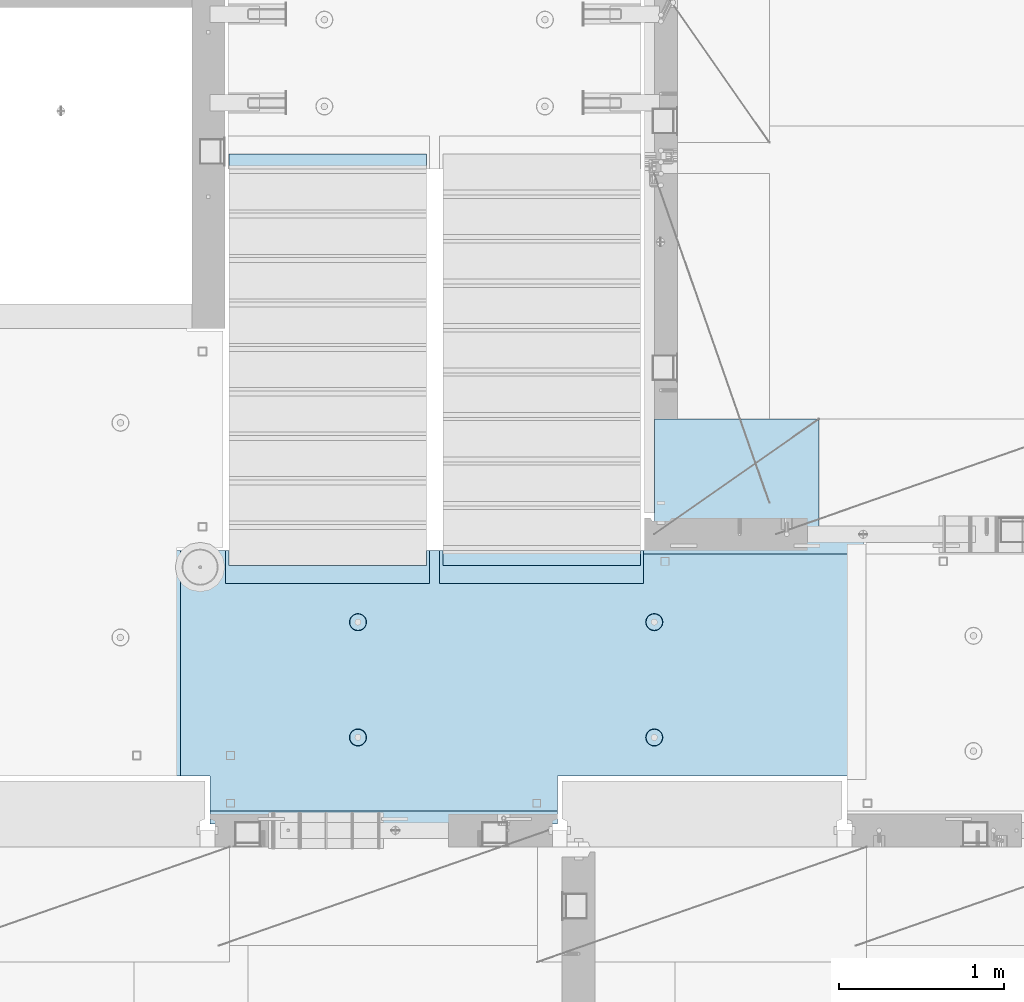
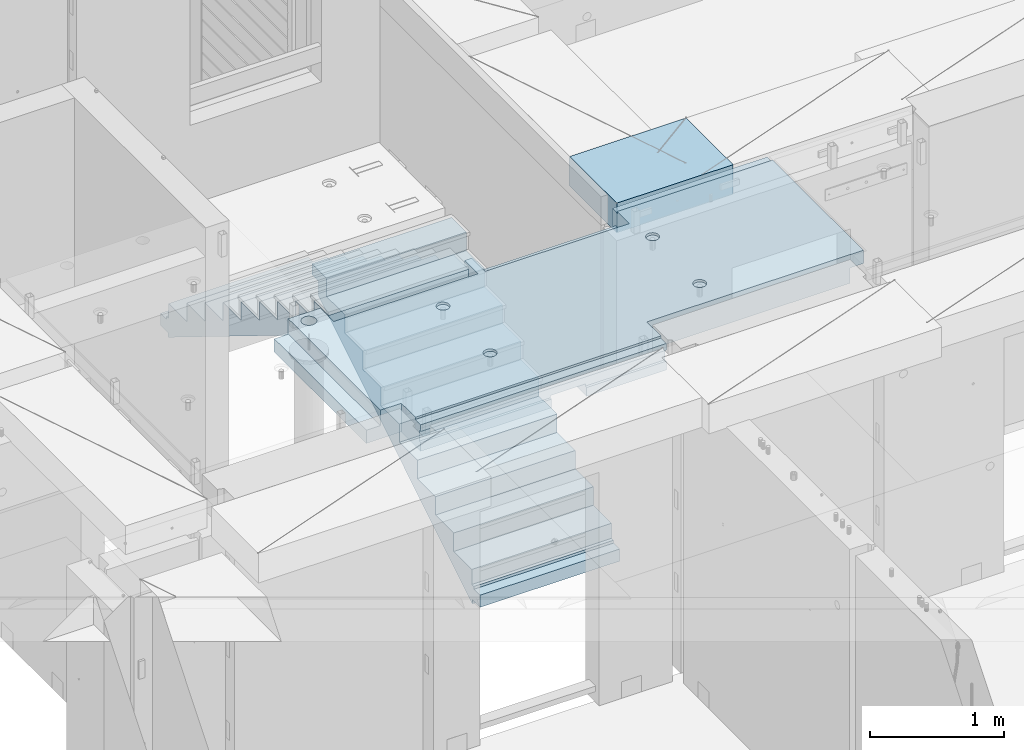
# One storey, part 187 of 325: 3 plates, 1 slab, 4 elements without a shape of their own.
"""IFC2X3 building model written with IfcOpenShell, lengths in millimetres."""

import ifcopenshell
import ifcopenshell.guid

model = None  # the IFC model being written
_history = None  # IfcOwnerHistory: only IFC2X3 demands one
_inside = {}  # id of a spatial element -> (the spatial element, [elements in it])
_under = {}  # id of a project, library or spatial element -> (it, [spatial elements below it])
_declared = {}  # id of a project -> (the project, [libraries it declares])
_typed = {}  # id of a type object -> (the type object, [elements of that type])
_made_of = {}  # id of a material, layer set ... -> (it, [elements and type objects made of it])


def new_model(schema):
    """Start an empty IFC model of exactly this schema.

    Asked for "IFC4X3", IfcOpenShell would pick the latest addendum, in which some entities
    have other attributes; the version numbers below select the first issue.
    IFC2X3 requires an IfcOwnerHistory on every rooted entity: one is made here for all.
    """
    global model, _history
    if schema == "IFC4X3":
        model = ifcopenshell.file(schema_version=(4, 3, 0, 0))
    else:
        model = ifcopenshell.file(schema=schema)
    _inside.clear()
    _under.clear()
    _declared.clear()
    _typed.clear()
    _made_of.clear()
    _history = None
    if model.schema == "IFC2X3":
        org = make("IfcOrganization", Name="unknown")
        user = make(
            "IfcPersonAndOrganization",
            ThePerson=make("IfcPerson", FamilyName="unknown"),
            TheOrganization=org,
        )
        app = make(
            "IfcApplication",
            ApplicationDeveloper=org,
            Version="unknown",
            ApplicationFullName="unknown",
            ApplicationIdentifier="unknown",
        )
        _history = make(
            "IfcOwnerHistory",
            OwningUser=user,
            OwningApplication=app,
            ChangeAction="ADDED",
            CreationDate=0,
        )
    return model


def make(cls, **values):
    """One entity of the class cls with the attributes given. An attribute that is None is left unset."""
    return model.create_entity(
        cls, **{name: value for name, value in values.items() if value is not None}
    )


def rooted(cls, **values):
    """An entity with a GlobalId (a new one), such as an element, a storey or a relation."""
    return make(cls, GlobalId=ifcopenshell.guid.new(), OwnerHistory=_history, **values)


def si_unit(unit_type, name, prefix=None):
    """IfcSIUnit, for example si_unit("LENGTHUNIT", "METRE", prefix="MILLI")."""
    return make("IfcSIUnit", UnitType=unit_type, Prefix=prefix, Name=name)


def assignment(units):
    """IfcUnitAssignment: the units of a project."""
    return None if units is None else make("IfcUnitAssignment", Units=units)


def point(xyz):
    """IfcCartesianPoint."""
    return None if xyz is None else make("IfcCartesianPoint", Coordinates=xyz)


def direction(xyz):
    """IfcDirection."""
    return None if xyz is None else make("IfcDirection", DirectionRatios=xyz)


def frame(location, z_axis=None, x_axis=None):
    """IfcAxis2Placement3D, a coordinate frame: its origin and axes. An axis left out is left unset."""
    return make(
        "IfcAxis2Placement3D",
        Location=point(location),
        Axis=direction(z_axis),
        RefDirection=direction(x_axis),
    )


def origin_with_axes():
    """The frame at (0, 0, 0) with the z axis (0, 0, 1) and the x axis (1, 0, 0) written out."""
    return frame((0.0, 0.0, 0.0), z_axis=(0.0, 0.0, 1.0), x_axis=(1.0, 0.0, 0.0))


def place(relative_to, where):
    """IfcLocalPlacement: puts the frame where relative to a parent placement (None: the world)."""
    return make(
        "IfcLocalPlacement", PlacementRelTo=relative_to, RelativePlacement=where
    )


def context(
    kind, dimensions, precision=None, world=None, true_north=None, identifier=None
):
    """IfcGeometricRepresentationContext, for example the 3D "Model" context."""
    return make(
        "IfcGeometricRepresentationContext",
        ContextIdentifier=identifier,
        ContextType=kind,
        CoordinateSpaceDimension=dimensions,
        Precision=precision,
        WorldCoordinateSystem=world,
        TrueNorth=true_north,
    )


def subcontext(parent, identifier, kind, view, scale=None):
    """IfcGeometricRepresentationSubContext, for example "Body" below "Model"."""
    return make(
        "IfcGeometricRepresentationSubContext",
        ContextIdentifier=identifier,
        ContextType=kind,
        ParentContext=parent,
        TargetScale=scale,
        TargetView=view,
    )


def project(units=None, contexts=None):
    """IfcProject with its units and contexts."""
    return rooted(
        "IfcProject",
        Name="project",
        RepresentationContexts=contexts,
        UnitsInContext=assignment(units),
    )


def spatial(cls, under=None, at=None, **own):
    """A site, building, storey or space (cls), placed at a placement, below another one or the project."""
    s = rooted(cls, ObjectPlacement=at, **own)
    if under is not None:
        _under.setdefault(under.id(), (under, []))[1].append(s)
    return s


def faces_of(points, faces, orient=None, outer=None):
    """IfcFace entities. A face is a list of loops; a loop is a list of indices into points, from 0.

    orient and outer hold one flag for each loop. By default every Orientation is true, the
    first loop of a face is its IfcFaceOuterBound and the others are IfcFaceBound.
    """
    made = []
    for i, loops in enumerate(faces):
        bounds = []
        for j, loop in enumerate(loops):
            is_outer = j == 0 if outer is None else outer[i][j]
            bounds.append(
                make(
                    "IfcFaceOuterBound" if is_outer else "IfcFaceBound",
                    Bound=make("IfcPolyLoop", Polygon=[points[k] for k in loop]),
                    Orientation=True if orient is None else orient[i][j],
                )
            )
        made.append(make("IfcFace", Bounds=bounds))
    return made


def faceted_brep(points, faces, orient=None, outer=None, voids=None):
    """IfcFacetedBrep: a solid bounded by flat faces; with voids (closed shells), ...WithVoids."""
    shared = [point(p) for p in points]
    hull = make("IfcClosedShell", CfsFaces=faces_of(shared, faces, orient, outer))
    if voids is None:
        return make("IfcFacetedBrep", Outer=hull)
    return make(
        "IfcFacetedBrepWithVoids",
        Outer=hull,
        Voids=[
            make(cls, CfsFaces=faces_of(shared, fs, o, b)) for cls, fs, o, b in voids
        ],
    )


def shape(context_of_items, identifier, shape_type, items):
    """IfcShapeRepresentation: the items that make up one representation, for example the "Body"."""
    return make(
        "IfcShapeRepresentation",
        ContextOfItems=context_of_items,
        RepresentationIdentifier=identifier,
        RepresentationType=shape_type,
        Items=items,
    )


def material(Name=None, Category=None):
    """IfcMaterial."""
    return make("IfcMaterial", Name=Name, Category=Category)


def made_of(thing, what):
    """Note that an element or type object is made of a material, layer set ...; save() writes the relation."""
    if what is not None:
        _made_of.setdefault(what.id(), (what, []))[1].append(thing)
    return thing


def type_object(cls, material=None, **own):
    """A type object (cls), such as IfcWallType, which elements share."""
    return made_of(rooted(cls, **own), material)


def element(
    cls,
    number,
    at=None,
    inside=None,
    cuts=None,
    type_object=None,
    material=None,
    context=None,
    identifier="Body",
    shape_type=None,
    held_by="IfcProductDefinitionShape",
    body=None,
    shapes=None,
    **own,
):
    """One element of the class cls, such as IfcWall. Its Tag is "e" and its number.

    at: its placement. inside: the storey or other place that contains it. cuts: it is an
    opening in that element (IfcRelVoidsElement). A single representation is given by context,
    identifier, shape_type and body (its items); several are given by shapes. held_by: the class
    of the entity that holds the representations. save() writes the other relations.
    """
    e = rooted(cls, Tag="e%d" % number, ObjectPlacement=at, **own)
    if body is not None:
        shapes = [shape(context, identifier, shape_type, body)]
    if shapes is not None:
        e.Representation = make(held_by, Representations=shapes)
    if inside is not None:
        _inside.setdefault(inside.id(), (inside, []))[1].append(e)
    if cuts is not None:
        rooted(
            "IfcRelVoidsElement", RelatingBuildingElement=cuts, RelatedOpeningElement=e
        )
    if type_object is not None:
        _typed.setdefault(type_object.id(), (type_object, []))[1].append(e)
    return made_of(e, material)


def aggregate(whole, parts):
    """IfcRelAggregates: a whole, such as a stair, and the parts it consists of."""
    return rooted("IfcRelAggregates", RelatingObject=whole, RelatedObjects=parts)


def save(model, path):
    """Write the relations noted so far, then the file.

    IfcRelAggregates (storeys below a building ...), IfcRelContainedInSpatialStructure (elements
    in a storey), IfcRelDefinesByType, IfcRelAssociatesMaterial and IfcRelDeclares: one each for
    every whole, place, type object, material and project.
    """
    for whole, parts in _under.values():
        aggregate(whole, parts)
    for where, things in _inside.values():
        rooted(
            "IfcRelContainedInSpatialStructure",
            RelatedElements=things,
            RelatingStructure=where,
        )
    for kind, things in _typed.values():
        rooted("IfcRelDefinesByType", RelatedObjects=things, RelatingType=kind)
    for what, things in _made_of.values():
        rooted("IfcRelAssociatesMaterial", RelatedObjects=things, RelatingMaterial=what)
    for by, libraries in _declared.values():
        rooted("IfcRelDeclares", RelatingContext=by, RelatedDefinitions=libraries)
    model.write(path)


model = new_model("IFC2X3")

# Units and contexts
model_context = context("Model", 3, precision=1e-05, world=origin_with_axes())
body_context = subcontext(model_context, "Body", "Model", "MODEL_VIEW")
ifc_project = project(units=[si_unit("LENGTHUNIT", "METRE", prefix="MILLI"), si_unit("AREAUNIT", "SQUARE_METRE"), si_unit("VOLUMEUNIT", "CUBIC_METRE"), si_unit("MASSUNIT", "GRAM", prefix="KILO"), si_unit("TIMEUNIT", "SECOND"), si_unit("PLANEANGLEUNIT", "RADIAN"), si_unit("SOLIDANGLEUNIT", "STERADIAN"), si_unit("THERMODYNAMICTEMPERATUREUNIT", "DEGREE_CELSIUS"), si_unit("LUMINOUSINTENSITYUNIT", "LUMEN")], contexts=[model_context])

# Site, building, storey
site_placement = place(None, origin_with_axes())
site = spatial("IfcSite", under=ifc_project, at=site_placement, CompositionType="ELEMENT")
building_placement = place(site_placement, origin_with_axes())
building = spatial("IfcBuilding", under=site, at=building_placement, CompositionType="ELEMENT")
storey_placement = place(building_placement, origin_with_axes())
storey = spatial("IfcBuildingStorey", under=building, at=storey_placement, Name="1", CompositionType="ELEMENT", Elevation=0.0)

# Assembly, slab
assembly_1_placement = place(storey_placement, origin_with_axes())
assembly_1 = element("IfcElementAssembly", 1, at=assembly_1_placement, inside=storey, AssemblyPlace="NOTDEFINED", PredefinedType="REINFORCEMENT_UNIT")
ifc_material_1 = material(Name="CONCRETE/C25/30")
slab_type = type_object("IfcSlabType", PredefinedType="NOTDEFINED")
slab_placement = place(assembly_1_placement, frame((23540.0159390845, 15510.0026483125, 84620.0), z_axis=(-0.999999999997437, -2.26400000064461e-06, 0.0), x_axis=(-2.2639999995273e-06, 0.999999999997437, 0.0)))
slab = element("IfcSlab", 2, at=slab_placement, type_object=slab_type, material=ifc_material_1, PredefinedType="FLOOR", context=body_context, shape_type="Brep", body=[
    faceted_brep([(-269.991394356101, 30.0, 2845.00213671412), (-79.9935682977648, 30.0, 2845.00213671301), (-79.9942474988402, 30.0, 2545.001661275), (-269.991475956112, 30.0, 2545.00209142873), (-79.9935682977648, 130.0, 2845.00213671301), (-269.991394356102, 50.0011356208415, 2845.00213671412), (-289.993566176285, 50.0011356208415, 2845.00213671423), (-289.993566176285, 130.0, 2845.00213671423), (-79.9942474988402, 130.0, 2545.001661275), (-289.994243058944, 130.0, 2545.00213671499), (-289.994243058944, 50.0011356208415, 2545.00213671499), (-269.991475956114, 50.0011356208415, 2545.00209142873), (250.667816023648, -110.0, 1223.00869116667), (264.606228919523, -110.0, 1230.11066726268), (275.667816023648, -110.0, 1241.1722543668), (282.76979211966, -110.0, 1255.11066726268), (285.216966304903, -110.0, 1270.56151698143), (282.769792119658, -110.0, 1286.01236670018), (275.667816023648, -110.0, 1299.95077959605), (264.606228919525, -110.0, 1311.01236670018), (250.667816023648, -110.0, 1318.11434279619), (235.216966304901, -110.0, 1320.56151698143), (219.766116586154, -110.0, 1318.11434279619), (205.827703690276, -110.0, 1311.01236670018), (194.766116586154, -110.0, 1299.95077959605), (187.664140490142, -110.0, 1286.01236670018), (185.216966304899, -110.0, 1270.56151698143), (187.664140490144, -110.0, 1255.11066726268), (194.766116586154, -110.0, 1241.1722543668), (205.827703690276, -110.0, 1230.11066726268), (219.766116586154, -110.0, 1223.00869116667), (235.216966304901, -110.0, 1220.56151698143), (251.370127374501, -130.0, 1220.84719908418), (235.216966304901, -130.0, 1218.2887897087), (265.942104492917, -130.0, 1228.27199227546), (277.506491010863, -130.0, 1239.83637879341), (284.931284202146, -130.0, 1254.40835591183), (287.489693577627, -130.0, 1270.56151698143), (284.931284202146, -130.0, 1286.71467805103), (277.506491010861, -130.0, 1301.28665516945), (265.942104492917, -130.0, 1312.85104168739), (251.370127374501, -130.0, 1320.27583487867), (235.216966304901, -130.0, 1322.83424425416), (219.063805235301, -130.0, 1320.27583487867), (204.491828116883, -130.0, 1312.85104168739), (192.927441598938, -130.0, 1301.28665516945), (185.502648407655, -130.0, 1286.71467805103), (182.944239032175, -130.0, 1270.56151698143), (185.502648407655, -130.0, 1254.40835591183), (192.92744159894, -130.0, 1239.83637879341), (204.491828116883, -130.0, 1228.27199227546), (219.063805235301, -130.0, 1220.84719908418), (1370.00988769532, 9.99999999994179, 4270.0029296875), (0.00703133410206647, 9.99999999994179, 4270.00341796875), (0.00594789032584231, 9.99999999994179, 4150.00335886026), (1370.00950450419, 9.99999999994179, 4150.0022190173), (1370.00988769532, 130.0, 4270.0029296875), (0.00703133410206647, 130.0, 4270.00341796875), (-289.995788574217, 50.0011356208415, 1860.01696777343), (-269.99166227209, 50.0011356208415, 1860.01689198933), (-289.995788574217, 130.0, 1860.01696777343), (1410.00403637765, -10.0000000000582, 115.00218916441), (-0.000334584017764428, -10.0000000000582, 115.003668258996), (-0.000334584015945438, 130.0, 115.003668258996), (1430.00436377147, 130.0, 115.002168181909), (1430.00283514406, 50.0011356437899, 115.002168184747), (1410.00403637764, 50.0011356208415, 115.002189163421), (1430.00659179688, 130.0, 1330.01220703125), (1370.00036621094, 130.0, 1330.01281738281), (1370.00036621094, -110.000000000073, 1330.01281738281), (1430.00659179688, -110.000000000073, 1330.01220703125), (1430.00656714066, -110.000000000073, 1.33804860524833e-08), (1350.00656713971, -110.000000000073, -1.09139364212751e-10), (1350.00656713971, -130.0, -9.31322574615479e-10), (0.0, -130.0, -3.63797880709171e-12), (0.0, -10.0, 0.0), (1410.00416932017, -10.0000000000582, 1.69893610291183e-09), (1410.00416932017, -49.9988643791585, 5.89352566748858e-10), (1430.00416932019, -49.9988643791585, 2.83398549072444e-09), (1430.00277003324, 50.0011356208415, 1270.01537795496), (1430.00277003324, -49.9988643791585, 1270.01537795496), (1410.00277003325, 50.0011356208415, 1270.01535591496), (1410.00277003325, -49.9988643791585, 1270.01535591496), (-0.00148380931932479, -130.0, 510.016937255856), (-0.00148380931932479, 130.0, 510.016937255856), (0.00156440050341189, -130.0, 1860.01586914062), (0.00156440050341189, 130.0, 1860.01586914062), (-209.991713751984, -130.000000000058, 1860.01666468411), (-209.996345203012, -130.0, 3970.01713194715), (-209.996345203012, -110.000000000058, 3970.01713194715), (-209.991713751984, -110.000000000058, 1860.01666468411), (-289.991027832028, -110.000000000058, 3970.01733398437), (-289.995788574217, -110.000000000058, 1860.01696777343), (-289.991027832028, -49.9988643791585, 3970.01733398437), (-289.995788574217, -49.9988643791585, 1860.01696777343), (-269.99166227209, -49.9988643791585, 1860.01689198933), (-289.991027832028, 50.0011356208415, 3970.01733398437), (-289.991027832028, 130.0, 3970.01733398437), (-269.991088351981, 50.0011356208415, 3970.01728347186), (-269.991088351981, -49.9988643791585, 3970.01728347186), (0.00432284502676339, -130.0, 3970.0166015625), (0.00432284502676339, 130.0, 3970.0166015625), (0.00594789032584231, -130.0, 4150.00335886026), (1370.00950450419, -130.000000000058, 4150.0022190173), (1370.00860847198, 9.99639270307671, 3875.01157736929), (1170.00318277859, 9.99639270307671, 3875.01203018158), (1170.00037541444, 9.99639270307671, 2635.01019913007), (1370.00459258838, 9.99639270307671, 2635.00974632052), (1370.00860847197, -130.000000000058, 3875.01157736929), (1170.00318277859, -130.000000000029, 3875.01203018158), (1170.00037541444, -130.000000000029, 2635.01019913007), (1370.00459258838, -130.000000000029, 2635.00974632052), (1370.00439827764, -130.000000000029, 2575.01157737549), (1170.00023957859, -130.000000000029, 2575.01203018491), (1170.00023957859, 9.99639270307671, 2575.01203018491), (1370.00439827764, 9.99639270307671, 2575.01157737549), (1169.99743221444, -130.000000000029, 1335.0101991334), (1169.99743221444, 9.99639270307671, 1335.0101991334), (1370.00038239405, 9.99639270307671, 1335.00974632672), (1370.00038239405, -110.000000000073, 1335.00974632672), (1350.00004294686, -110.000000000073, 1335.00979160748), (1350.00004294686, -130.000000000073, 1335.00979160748), (920.332855772751, -110.0, 1318.11282667454), (906.394410719273, -110.0, 1311.01091369173), (895.332773528397, -110.0, 1299.94937667459), (888.230734319324, -110.0, 1286.01099593661), (885.78349017266, -110.0, 1270.56015729882), (888.230594396427, -110.0, 1255.10929649942), (895.332507379233, -110.0, 1241.17085144594), (906.394044396377, -110.0, 1230.10921425507), (920.332425134358, -110.0, 1223.00717504599), (935.783263772144, -110.0, 1220.55993089933), (951.234124571543, -110.0, 1223.0070351231), (965.172569625021, -110.0, 1230.10894810591), (976.234206815898, -110.0, 1241.17048512305), (983.33624602497, -110.0, 1255.10886586103), (985.783490171634, -110.0, 1270.55970449882), (983.336385947867, -110.0, 1286.01056529821), (976.234472965061, -110.0, 1299.94901035169), (965.172935947918, -110.0, 1311.01064754257), (951.234555209936, -110.0, 1318.11268675164), (935.783716572147, -110.0, 1320.5599308983), (951.936426135147, -130.0, 1220.84553986057), (935.783253481237, -130.0, 1218.28720362663), (966.508436872882, -130.0, 1228.27026706986), (978.072875754253, -130.0, 1239.83460122415), (985.497734927369, -130.0, 1254.40654472295), (988.05621744434, -130.0, 1270.55969420791), (985.497881210395, -130.0, 1286.71286686182), (978.073154001104, -130.0, 1301.28487759955), (966.508819846818, -130.0, 1312.84931648092), (951.936876348012, -130.0, 1320.27417565404), (935.783726863054, -130.0, 1322.83265817101), (919.630554209147, -130.0, 1320.27432193707), (905.058543471412, -130.0, 1312.84959472777), (893.494104590041, -130.0, 1301.28526057349), (886.069245416922, -130.0, 1286.71331707469), (883.510762899954, -130.0, 1270.56016758973), (886.069099133892, -130.0, 1254.40699493582), (893.49382634319, -130.0, 1239.83498419809), (905.058160497476, -130.0, 1228.27054531671), (919.630103996282, -130.0, 1220.84568614359), (920.336931380272, -110.0, 3118.29282666992), (906.398486326791, -110.0, 3111.19091368712), (895.336849135918, -110.0, 3100.12937666997), (888.234809926846, -110.0, 3086.19099593199), (885.787565780181, -110.0, 3070.7401572942), (888.234670003949, -110.0, 3055.28929649481), (895.336582986754, -110.0, 3041.35085144133), (906.398120003898, -110.0, 3030.28921425045), (920.33650074188, -110.0, 3023.18717504138), (935.787339379665, -110.0, 3020.73993089472), (951.238200179065, -110.0, 3023.18703511849), (965.176645232543, -110.0, 3030.28894810129), (976.238282423419, -110.0, 3041.35048511844), (983.340321632491, -110.0, 3055.28886585642), (985.787565779156, -110.0, 3070.7397044942), (983.340461555388, -110.0, 3086.1905652936), (976.238548572583, -110.0, 3100.12901034708), (965.177011555439, -110.0, 3111.19064753796), (951.238630817454, -110.0, 3118.29268674703), (935.787792179664, -110.0, 3120.73993089369), (951.940501742669, -130.000000000015, 3021.02553985595), (935.787329088758, -130.000000000015, 3018.46720362201), (966.512512480404, -130.000000000015, 3028.45026706525), (978.076951361778, -130.000000000015, 3040.01460121954), (985.50181053489, -130.000000000015, 3054.58654471834), (988.060293051862, -130.000000000015, 3070.73969420329), (985.501956817916, -130.000000000015, 3086.89286685721), (978.077229608625, -130.000000000015, 3101.46487759494), (966.51289545434, -130.000000000015, 3113.02931647631), (951.940951955534, -130.000000000015, 3120.45417564943), (935.787802470575, -130.000000000015, 3123.01265816639), (919.634629816665, -130.000000000015, 3120.45432193246), (905.062619078933, -130.000000000015, 3113.02959472316), (893.498180197559, -130.000000000015, 3101.46526056888), (886.07332102444, -130.000000000015, 3086.89331707007), (883.514838507475, -130.000000000015, 3070.74016758511), (886.073174741414, -130.000000000015, 3054.5869949312), (893.497901950712, -130.000000000015, 3040.01498419347), (905.062236104997, -130.000000000015, 3028.4505453121), (919.634179603803, -130.000000000015, 3021.02568613898), (250.671891631169, -110.0, 3023.18869116206), (264.610304527045, -110.0, 3030.29066725807), (275.671891631167, -110.0, 3041.35225436219), (282.773867727179, -110.0, 3055.29066725806), (285.221041912424, -110.0, 3070.74151697681), (282.773867727179, -110.0, 3086.19236669556), (275.671891631169, -110.0, 3100.13077959144), (264.610304527047, -110.0, 3111.19236669556), (250.671891631169, -110.0, 3118.29434279157), (235.221041912422, -110.0, 3120.74151697681), (219.770192193675, -110.0, 3118.29434279157), (205.831779297798, -110.0, 3111.19236669556), (194.770192193675, -110.0, 3100.13077959144), (187.668216097663, -110.0, 3086.19236669556), (185.22104191242, -110.0, 3070.74151697681), (187.668216097663, -110.0, 3055.29066725806), (194.770192193673, -110.0, 3041.35225436219), (205.831779297798, -110.0, 3030.29066725807), (219.770192193673, -110.0, 3023.18869116206), (235.221041912422, -110.0, 3020.74151697681), (251.374202982022, -130.0, 3021.02719907957), (235.221041912422, -130.0, 3018.46878970409), (265.946180100438, -130.0, 3028.45199227085), (277.510566618384, -130.0, 3040.0163787888), (284.935359809668, -130.0, 3054.58835590722), (287.493769185148, -130.0, 3070.74151697681), (284.935359809668, -130.0, 3086.89467804641), (277.510566618383, -130.0, 3101.46665516483), (265.946180100438, -130.0, 3113.03104168278), (251.374202982022, -130.0, 3120.45583487406), (235.22104191242, -130.0, 3123.01424424954), (219.067880842822, -130.0, 3120.45583487406), (204.495903724404, -130.0, 3113.03104168278), (192.93151720646, -130.0, 3101.46665516483), (185.506724015177, -130.0, 3086.89467804641), (182.948314639694, -130.0, 3070.74151697681), (185.506724015177, -130.0, 3054.58835590722), (192.93151720646, -130.0, 3040.0163787888), (204.495903724404, -130.0, 3028.45199227085), (219.06788084282, -130.0, 3021.02719907957), (1234.74413944682, -130.000000000029, 3981.4733287671), (1221.47026497402, -130.000000000029, 3994.74726334413), (1212.94793152671, -130.000000000029, 4011.47337811379), (1210.0113644813, -130.000000000029, 4030.01440442472), (1212.94801548044, -130.000000000029, 4048.55541743869), (1221.47042466352, -130.000000000029, 4065.28149361904), (1234.74435924055, -130.000000000029, 4078.55536809184), (1251.47047401021, -130.000000000029, 4087.07770153915), (1270.01150032114, -130.000000000029, 4090.01426858456), (1288.55251333511, -130.000000000029, 4087.07761758541), (1305.27858951547, -130.000000000029, 4078.55520840234), (1318.55246398826, -130.000000000029, 4065.28127382531), (1327.07479743557, -130.000000000029, 4048.55515905565), (1330.01136448099, -130.000000000029, 4030.01413274472), (1327.07471348184, -130.000000000029, 4011.47311973075), (1318.55230429877, -130.000000000029, 3994.74704355039), (1305.27836972173, -130.000000000029, 3981.4731690776), (1288.55225495208, -130.000000000029, 3972.95083563029), (1270.01122864114, -130.000000000029, 3970.01426858487), (1251.47021562717, -130.000000000029, 3972.95091958403), (1305.27836972173, 130.0, 3981.4731690776), (1288.55225495208, 130.0, 3972.95083563029), (1318.55230429877, 130.0, 3994.74704355039), (1327.07471348184, 130.0, 4011.47311973075), (1330.01136448099, 130.0, 4030.01413274472), (1327.07479743557, 130.0, 4048.55515905565), (1318.55246398826, 130.0, 4065.28127382531), (1305.27858951547, 130.0, 4078.55520840234), (1288.55251333511, 130.0, 4087.07761758541), (1270.01150032114, 130.0, 4090.01426858456), (1251.47047401021, 130.0, 4087.07770153915), (1234.74435924055, 130.0, 4078.55536809184), (1221.47042466352, 130.0, 4065.28149361904), (1212.94801548044, 130.0, 4048.55541743869), (1210.0113644813, 130.0, 4030.01440442472), (1212.94793152671, 130.0, 4011.47337811379), (1221.47026497402, 130.0, 3994.74726334413), (1234.74413944682, 130.0, 3981.4733287671), (1251.47021562717, 130.0, 3972.95091958403), (1270.01122864114, 130.0, 3970.01426858487)], [[[0, 1, 2, 3]], [[4, 1, 0, 5, 6, 7]], [[8, 2, 1, 4]], [[9, 10, 11, 3, 2, 8]], [[12, 13, 14, 15, 16, 17, 18, 19, 20, 21, 22, 23, 24, 25, 26, 27, 28, 29, 30, 31]], [[32, 12, 31, 33]], [[34, 13, 12, 32]], [[35, 14, 13, 34]], [[36, 15, 14, 35]], [[37, 16, 15, 36]], [[38, 17, 16, 37]], [[39, 18, 17, 38]], [[40, 19, 18, 39]], [[41, 20, 19, 40]], [[42, 21, 20, 41]], [[43, 22, 21, 42]], [[44, 23, 22, 43]], [[45, 24, 23, 44]], [[46, 25, 24, 45]], [[47, 26, 25, 46]], [[48, 27, 26, 47]], [[49, 28, 27, 48]], [[50, 29, 28, 49]], [[51, 30, 29, 50]], [[33, 31, 30, 51]], [[52, 53, 54, 55]], [[56, 57, 53, 52]], [[58, 59, 11, 10]], [[60, 58, 10, 9]], [[61, 62, 63, 64, 65, 66]], [[67, 68, 69, 70]], [[71, 72, 73, 74, 75, 76, 77, 78]], [[79, 65, 64, 67, 70, 71, 78, 80]], [[65, 79, 81, 66]], [[80, 82, 81, 79]], [[78, 77, 82, 80]], [[76, 61, 66, 81, 82, 77]], [[75, 62, 61, 76]], [[74, 83, 84, 63, 62, 75]], [[83, 85, 86, 84]], [[87, 88, 89, 90]], [[90, 89, 91, 92]], [[92, 91, 93, 94]], [[58, 60, 86, 85, 87, 90, 92, 94, 95, 59]], [[96, 97, 7, 6]], [[98, 96, 6, 5]], [[59, 95, 99, 98, 5, 0, 3, 11]], [[94, 93, 99, 95]], [[91, 89, 88, 100, 101, 97, 96, 98, 99, 93]], [[53, 57, 101, 100, 102, 54]], [[103, 55, 54, 102]], [[104, 105, 106, 107]], [[108, 109, 105, 104]], [[110, 106, 105, 109]], [[111, 107, 106, 110]], [[112, 113, 114, 115]], [[116, 117, 114, 113]], [[115, 114, 117, 118]], [[69, 68, 56, 52, 55, 103, 108, 104, 107, 111, 112, 115, 118, 119]], [[72, 71, 70, 69, 119, 120]], [[73, 72, 120, 121]], [[119, 118, 117, 116, 121, 120]], [[122, 123, 124, 125, 126, 127, 128, 129, 130, 131, 132, 133, 134, 135, 136, 137, 138, 139, 140, 141]], [[142, 132, 131, 143]], [[144, 133, 132, 142]], [[145, 134, 133, 144]], [[146, 135, 134, 145]], [[147, 136, 135, 146]], [[148, 137, 136, 147]], [[149, 138, 137, 148]], [[150, 139, 138, 149]], [[151, 140, 139, 150]], [[152, 141, 140, 151]], [[153, 122, 141, 152]], [[154, 123, 122, 153]], [[155, 124, 123, 154]], [[156, 125, 124, 155]], [[157, 126, 125, 156]], [[158, 127, 126, 157]], [[159, 128, 127, 158]], [[160, 129, 128, 159]], [[161, 130, 129, 160]], [[143, 131, 130, 161]], [[162, 163, 164, 165, 166, 167, 168, 169, 170, 171, 172, 173, 174, 175, 176, 177, 178, 179, 180, 181]], [[182, 172, 171, 183]], [[184, 173, 172, 182]], [[185, 174, 173, 184]], [[186, 175, 174, 185]], [[187, 176, 175, 186]], [[188, 177, 176, 187]], [[189, 178, 177, 188]], [[190, 179, 178, 189]], [[191, 180, 179, 190]], [[192, 181, 180, 191]], [[193, 162, 181, 192]], [[194, 163, 162, 193]], [[195, 164, 163, 194]], [[196, 165, 164, 195]], [[197, 166, 165, 196]], [[198, 167, 166, 197]], [[199, 168, 167, 198]], [[200, 169, 168, 199]], [[201, 170, 169, 200]], [[183, 171, 170, 201]], [[202, 203, 204, 205, 206, 207, 208, 209, 210, 211, 212, 213, 214, 215, 216, 217, 218, 219, 220, 221]], [[222, 202, 221, 223]], [[224, 203, 202, 222]], [[225, 204, 203, 224]], [[226, 205, 204, 225]], [[227, 206, 205, 226]], [[228, 207, 206, 227]], [[229, 208, 207, 228]], [[230, 209, 208, 229]], [[231, 210, 209, 230]], [[232, 211, 210, 231]], [[233, 212, 211, 232]], [[234, 213, 212, 233]], [[235, 214, 213, 234]], [[236, 215, 214, 235]], [[237, 216, 215, 236]], [[238, 217, 216, 237]], [[239, 218, 217, 238]], [[240, 219, 218, 239]], [[241, 220, 219, 240]], [[223, 221, 220, 241]], [[113, 112, 111, 110, 109, 108, 103, 102, 100, 88, 87, 85, 83, 74, 73, 121, 116], [240, 239, 238, 237, 236, 235, 234, 233, 232, 231, 230, 229, 228, 227, 226, 225, 224, 222, 223, 241], [200, 199, 198, 197, 196, 195, 194, 193, 192, 191, 190, 189, 188, 187, 186, 185, 184, 182, 183, 201], [160, 159, 158, 157, 156, 155, 154, 153, 152, 151, 150, 149, 148, 147, 146, 145, 144, 142, 143, 161], [50, 49, 48, 47, 46, 45, 44, 43, 42, 41, 40, 39, 38, 37, 36, 35, 34, 32, 33, 51], [242, 243, 244, 245, 246, 247, 248, 249, 250, 251, 252, 253, 254, 255, 256, 257, 258, 259, 260, 261]], [[258, 262, 263, 259]], [[257, 264, 262, 258]], [[256, 265, 264, 257]], [[255, 266, 265, 256]], [[254, 267, 266, 255]], [[253, 268, 267, 254]], [[252, 269, 268, 253]], [[251, 270, 269, 252]], [[250, 271, 270, 251]], [[249, 272, 271, 250]], [[248, 273, 272, 249]], [[247, 274, 273, 248]], [[246, 275, 274, 247]], [[245, 276, 275, 246]], [[244, 277, 276, 245]], [[243, 278, 277, 244]], [[242, 279, 278, 243]], [[261, 280, 279, 242]], [[260, 281, 280, 261]], [[259, 263, 281, 260]], [[7, 97, 101, 57, 56, 68, 67, 64, 63, 84, 86, 60, 9, 8, 4], [262, 264, 265, 266, 267, 268, 269, 270, 271, 272, 273, 274, 275, 276, 277, 278, 279, 280, 281, 263]]]),
])
aggregate(assembly_1, [slab])

# Assembly, plate
assembly_2_placement = place(storey_placement, origin_with_axes())
assembly_2 = element("IfcElementAssembly", 3, at=assembly_2_placement, inside=storey, Name="E9", AssemblyPlace="NOTDEFINED", PredefinedType="NOTDEFINED")
ifc_material_2 = material(Name="Undefined/C32/40")
plate_type_1 = type_object("IfcPlateType", PredefinedType="NOTDEFINED")
plate_1_placement = place(assembly_2_placement, frame((20285.0002457424, 19199.9998138874, 83260.0), z_axis=(0.0, -1.0, 0.0), x_axis=(0.0, 0.0, -1.0)))
plate_1 = element("IfcPlate", 4, at=plate_1_placement, type_object=plate_type_1, material=ifc_material_2, Name="E9", context=body_context, shape_type="Brep", body=[
    faceted_brep([(0.0, -600.0, 0.0), (0.0, -600.0, 30.0), (0.0, 600.0, 30.0), (0.0, 600.0, 0.0), (-136.699996948242, -600.0, 30.0), (-136.699996948242, 600.0, 30.0), (-136.699996948242, -600.0, 300.0), (-136.699996948242, 600.0, 300.0), (-303.399993896484, -600.0, 300.0), (-303.399993896484, 600.0, 300.0), (-303.399993896484, -600.0, 570.0), (-303.399993896484, 600.0, 570.0), (-470.100006103516, -600.0, 570.0), (-470.100006103516, 600.0, 570.0), (-470.100006103516, -600.0, 840.0), (-470.100006103516, 600.0, 840.0), (-636.799987792969, -600.0, 840.0), (-636.799987792969, 600.0, 840.0), (-636.799987792969, -600.0, 1110.0), (-636.799987792969, 600.0, 1110.0), (-803.5, -600.0, 1110.0), (-803.5, 600.0, 1110.0), (-803.5, -600.0, 1380.0), (-803.5, 600.0, 1380.0), (-970.200012207031, -600.0, 1380.0), (-970.200012207031, 600.0, 1380.0), (-970.200012207031, -600.0, 1650.0), (-970.200012207031, 600.0, 1650.0), (-1136.90002441406, -600.0, 1650.0), (-1136.90002441406, 600.0, 1650.0), (-1136.90002441406, -600.0, 1920.0), (-1136.90002441406, 600.0, 1920.0), (-1303.59997558594, -600.0, 1920.0), (-1303.59997558594, 600.0, 1920.0), (-1303.59997558594, -600.0, 2190.0), (-1303.59997558594, 600.0, 2190.0), (-1470.30004882813, -600.0, 2190.0), (-1470.30004882813, 600.0, 2190.0), (-1470.30004882813, -600.0, 2410.0), (-1470.30004882813, 600.0, 2410.0), (-1370.30004882813, -600.0, 2410.0), (-1370.30004882813, 600.0, 2410.0), (-1370.30004882813, -600.0, 2310.0), (-1370.30004882813, 600.0, 2310.0), (-1236.65991210938, -600.0, 2310.0), (-1236.65991210938, 600.0, 2310.0), (170.0, -600.0, 31.6665592193604), (170.0, 600.0, 31.6665592193604), (170.0, -600.0, 20.0), (170.0, 600.0, 20.0), (135.0, -600.0, 20.0), (135.0, 600.0, 20.0), (135.0, -600.0, -90.0), (135.0, 600.0, -90.0), (25.0, -600.0, -90.0), (25.0, 600.0, -90.0), (25.0, -600.0, 0.0), (25.0, 600.0, 0.0)], [[[0, 1, 2, 3]], [[1, 4, 5, 2]], [[4, 6, 7, 5]], [[6, 8, 9, 7]], [[8, 10, 11, 9]], [[10, 12, 13, 11]], [[12, 14, 15, 13]], [[14, 16, 17, 15]], [[16, 18, 19, 17]], [[18, 20, 21, 19]], [[20, 22, 23, 21]], [[22, 24, 25, 23]], [[24, 26, 27, 25]], [[26, 28, 29, 27]], [[28, 30, 31, 29]], [[30, 32, 33, 31]], [[32, 34, 35, 33]], [[34, 36, 37, 35]], [[36, 38, 39, 37]], [[38, 40, 41, 39]], [[40, 42, 43, 41]], [[42, 44, 45, 43]], [[44, 46, 47, 45]], [[46, 48, 49, 47]], [[48, 50, 51, 49]], [[50, 52, 53, 51]], [[52, 54, 55, 53]], [[54, 56, 57, 55]], [[56, 0, 3, 57]], [[5, 7, 9, 11, 13, 15, 17, 19, 21, 23, 25, 27, 29, 31, 33, 35, 37, 39, 41, 43, 45, 47, 49, 51, 53, 55, 57, 3, 2]], [[56, 54, 52, 50, 48, 46, 44, 42, 40, 38, 36, 34, 32, 30, 28, 26, 24, 22, 20, 18, 16, 14, 12, 10, 8, 6, 4, 1, 0]]]),
])
aggregate(assembly_2, [plate_1])

assembly_3_placement = place(storey_placement, origin_with_axes())
assembly_3 = element("IfcElementAssembly", 5, at=assembly_3_placement, inside=storey, Name="E9", AssemblyPlace="NOTDEFINED", PredefinedType="NOTDEFINED")
plate_2_placement = place(assembly_3_placement, frame((21585.002175553, 16880.001025346, 81759.7036072969), z_axis=(0.0, 1.0, 0.0), x_axis=(0.0, 0.0, -1.0)))
plate_2 = element("IfcPlate", 6, at=plate_2_placement, type_object=plate_type_1, material=ifc_material_2, Name="E9", context=body_context, shape_type="Brep", body=[
    faceted_brep([(0.0, -600.0, 0.0), (0.0, -600.0, 30.0), (0.0, 600.0, 30.0), (0.0, 600.0, 0.0), (-136.699996948242, -600.0, 30.0), (-136.699996948242, 600.0, 30.0), (-136.699996948242, -600.0, 300.0), (-136.699996948242, 600.0, 300.0), (-303.399993896484, -600.0, 300.0), (-303.399993896484, 600.0, 300.0), (-303.399993896484, -600.0, 570.0), (-303.399993896484, 600.0, 570.0), (-470.100006103516, -600.0, 570.0), (-470.100006103516, 600.0, 570.0), (-470.100006103516, -600.0, 840.0), (-470.100006103516, 600.0, 840.0), (-636.799987792969, -600.0, 840.0), (-636.799987792969, 600.0, 840.0), (-636.799987792969, -600.0, 1110.0), (-636.799987792969, 600.0, 1110.0), (-803.5, -600.0, 1110.0), (-803.5, 600.0, 1110.0), (-803.5, -600.0, 1380.0), (-803.5, 600.0, 1380.0), (-970.200012207031, -600.0, 1380.0), (-970.200012207031, 600.0, 1380.0), (-970.200012207031, -600.0, 1650.0), (-970.200012207031, 600.0, 1650.0), (-1136.90002441406, -600.0, 1650.0), (-1136.90002441406, 600.0, 1650.0), (-1136.90002441406, -600.0, 1920.0), (-1136.90002441406, 600.0, 1920.0), (-1303.59997558594, -600.0, 1920.0), (-1303.59997558594, 600.0, 1920.0), (-1303.59997558594, -600.0, 2190.0), (-1303.59997558594, 600.0, 2190.0), (-1470.30004882813, -600.0, 2190.0), (-1470.30004882813, 600.0, 2190.0), (-1470.30004882813, -600.0, 2410.0), (-1470.30004882813, 600.0, 2410.0), (-1370.30004882813, -600.0, 2410.0), (-1370.30004882813, 600.0, 2410.0), (-1370.30004882813, -600.0, 2310.0), (-1370.30004882813, 600.0, 2310.0), (-1236.65991210938, -600.0, 2310.0), (-1236.65991210938, 600.0, 2310.0), (170.0, -600.0, 31.6665592193604), (170.0, 600.0, 31.6665592193604), (170.0, -600.0, 20.0), (170.0, 600.0, 20.0), (135.0, -600.0, 20.0), (135.0, 600.0, 20.0), (135.0, -600.0, -90.0), (135.0, 600.0, -90.0), (25.0, -600.0, -90.0), (25.0, 600.0, -90.0), (25.0, -600.0, 0.0), (25.0, 600.0, 0.0)], [[[0, 1, 2, 3]], [[1, 4, 5, 2]], [[4, 6, 7, 5]], [[6, 8, 9, 7]], [[8, 10, 11, 9]], [[10, 12, 13, 11]], [[12, 14, 15, 13]], [[14, 16, 17, 15]], [[16, 18, 19, 17]], [[18, 20, 21, 19]], [[20, 22, 23, 21]], [[22, 24, 25, 23]], [[24, 26, 27, 25]], [[26, 28, 29, 27]], [[28, 30, 31, 29]], [[30, 32, 33, 31]], [[32, 34, 35, 33]], [[34, 36, 37, 35]], [[36, 38, 39, 37]], [[38, 40, 41, 39]], [[40, 42, 43, 41]], [[42, 44, 45, 43]], [[44, 46, 47, 45]], [[46, 48, 49, 47]], [[48, 50, 51, 49]], [[50, 52, 53, 51]], [[52, 54, 55, 53]], [[54, 56, 57, 55]], [[56, 0, 3, 57]], [[5, 7, 9, 11, 13, 15, 17, 19, 21, 23, 25, 27, 29, 31, 33, 35, 37, 39, 41, 43, 45, 47, 49, 51, 53, 55, 57, 3, 2]], [[56, 54, 52, 50, 48, 46, 44, 42, 40, 38, 36, 34, 32, 30, 28, 26, 24, 22, 20, 18, 16, 14, 12, 10, 8, 6, 4, 1, 0]]]),
])
aggregate(assembly_3, [plate_2])

assembly_4_placement = place(storey_placement, origin_with_axes())
assembly_4 = element("IfcElementAssembly", 7, at=assembly_4_placement, inside=storey, Name="Steel Assembly", AssemblyPlace="NOTDEFINED", PredefinedType="NOTDEFINED")
ifc_material_3 = material()
plate_type_2 = type_object("IfcPlateType", PredefinedType="NOTDEFINED")
plate_3_placement = place(assembly_4_placement, frame((22270.0, 16979.9999999293, 84595.3), z_axis=(0.0, 1.0, 0.0), x_axis=(1.0, 0.0, 0.0)))
plate_3 = element("IfcPlate", 8, at=plate_3_placement, type_object=plate_type_2, material=ifc_material_3, Name="RE1_1/2", context=body_context, shape_type="Brep", body=[
    faceted_brep([(1.81898940354586e-12, -135.0, 1.81898940354586e-12), (0.0, -135.0, 699.999999999996), (0.0, 135.0, 699.999999999996), (1.81898940354586e-12, 135.0, 1.81898940354586e-12), (999.99951171875, -135.0, 700.0), (999.99951171875, 135.0, 700.0), (1000.0, -135.0, 0.0), (1000.0, 135.0, 0.0)], [[[0, 1, 2, 3]], [[1, 4, 5, 2]], [[4, 6, 7, 5]], [[6, 0, 3, 7]], [[5, 7, 3, 2]], [[6, 4, 1, 0]]]),
])
aggregate(assembly_4, [plate_3])

save(model, "model.ifc")
